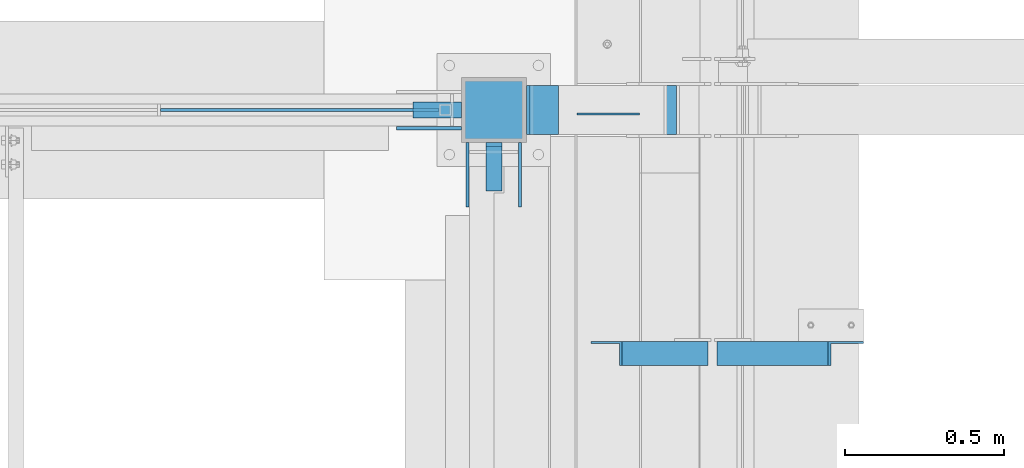
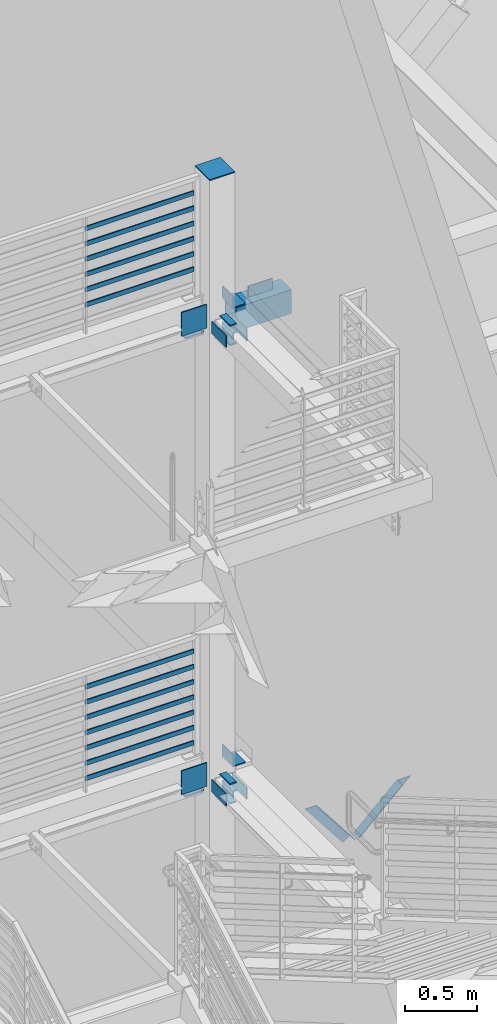
# One storey, part 878 of 1179: 32 beams, 2 members, 9 elements without a shape of their own.
"""IFC2X3 building model written with IfcOpenShell, lengths in millimetres."""

from ifc_helpers import new_model, si_unit, frame, origin_with_axes, place, context, subcontext, project, spatial, faceted_brep, material, type_object, element, aggregate, save


model = new_model("IFC2X3")

# Units and contexts
model_context = context("Model", 3, precision=1e-05, world=origin_with_axes())
body_context = subcontext(model_context, "Body", "Model", "MODEL_VIEW")
ifc_project = project(units=[si_unit("LENGTHUNIT", "METRE", prefix="MILLI"), si_unit("AREAUNIT", "SQUARE_METRE"), si_unit("VOLUMEUNIT", "CUBIC_METRE"), si_unit("MASSUNIT", "GRAM", prefix="KILO"), si_unit("TIMEUNIT", "SECOND"), si_unit("PLANEANGLEUNIT", "RADIAN"), si_unit("SOLIDANGLEUNIT", "STERADIAN"), si_unit("THERMODYNAMICTEMPERATUREUNIT", "DEGREE_CELSIUS"), si_unit("LUMINOUSINTENSITYUNIT", "LUMEN")], contexts=[model_context])

# Site, building, storey
site_placement = place(None, origin_with_axes())
site = spatial("IfcSite", under=ifc_project, at=site_placement, CompositionType="ELEMENT")
building_placement = place(site_placement, origin_with_axes())
building = spatial("IfcBuilding", under=site, at=building_placement, Name="Undefined", CompositionType="ELEMENT")
storey_placement = place(building_placement, origin_with_axes())
storey = spatial("IfcBuildingStorey", under=building, at=storey_placement, Name="Undefined", CompositionType="ELEMENT", Elevation=0.0)

# Assembly, beam
assembly_1_placement = place(storey_placement, origin_with_axes())
assembly_1 = element("IfcElementAssembly", 1, at=assembly_1_placement, inside=storey, Name="PLATE", AssemblyPlace="NOTDEFINED", PredefinedType="RIGID_FRAME")
ifc_material_1 = material(Name="STEEL/A572-GR.50")
beam_type_1 = type_object("IfcBeamType", PredefinedType="NOTDEFINED")
beam_1_placement = place(assembly_1_placement, frame((-254.000000000004, 37388.8, 8051.8), z_axis=(1.0, 0.0, 0.0), x_axis=(0.0, 1.0, 0.0)))
beam_1 = element("IfcBeam", 2, at=beam_1_placement, type_object=beam_type_1, material=ifc_material_1, Name="PLATE", context=body_context, shape_type="Brep", body=[
    faceted_brep([(152.400000000001, -6.35000000000036, 25.4), (152.400000000001, -6.35000000000036, -25.4), (139.700000000004, 6.35000000000036, -25.4), (139.700000000004, 6.35000000000036, 25.4), (0.0, -6.35000000000036, -25.4000000000015), (0.0, -6.35000000000036, 25.4000000000015), (0.0, 6.35000000000036, 25.4000000000015), (0.0, 6.35000000000036, -25.4000000000015)], [[[0, 1, 2, 3]], [[4, 5, 6, 7]], [[6, 5, 0, 3]], [[7, 6, 3, 2]], [[4, 7, 2, 1]], [[5, 4, 1, 0]]]),
])
aggregate(assembly_1, [beam_1])

# Assembly, beams
assembly_2_placement = place(storey_placement, origin_with_axes())
assembly_2 = element("IfcElementAssembly", 3, at=assembly_2_placement, inside=storey, Name="COLUMN", AssemblyPlace="NOTDEFINED", PredefinedType="RIGID_FRAME")
beam_2_placement = place(assembly_2_placement, frame((-253.999996662751, 37388.8, 7886.7), z_axis=(1.0, 0.0, 0.0), x_axis=(0.0, 1.0, 0.0)))
beam_2 = element("IfcBeam", 4, at=beam_2_placement, type_object=beam_type_1, material=ifc_material_1, Name="PLATE", context=body_context, shape_type="Brep", body=[
    faceted_brep([(152.399999999998, 6.35000000000036, 25.4000000000015), (139.699999999998, -6.35000000000036, 25.4000000000015), (139.699999999998, -6.35000000000036, -25.4000000000015), (152.399999999998, 6.35000000000036, -25.4000000000015), (0.0, -6.35000000000036, -25.4000000000015), (0.0, -6.35000000000036, 25.4000000000015), (0.0, 6.35000000000036, 25.4000000000015), (0.0, 6.35000000000036, -25.4000000000015)], [[[0, 1, 2, 3]], [[4, 5, 6, 7]], [[7, 6, 0, 3]], [[4, 7, 3, 2]], [[5, 4, 2, 1]], [[6, 5, 1, 0]]]),
])
beam_3_placement = place(assembly_2_placement, frame((-254.000000000004, 37388.8, 3975.10000002185), z_axis=(1.0, 0.0, 0.0), x_axis=(0.0, 1.0, 0.0)))
beam_3 = element("IfcBeam", 5, at=beam_3_placement, type_object=beam_type_1, material=ifc_material_1, Name="PLATE", context=body_context, shape_type="Brep", body=[
    faceted_brep([(152.399999999998, 6.35000000000036, 25.4000000000015), (139.699999999998, -6.35000000000036, 25.4000000000015), (139.699999999998, -6.35000000000036, -25.4000000000015), (152.399999999998, 6.35000000000036, -25.4000000000015), (0.0, -6.35000000000036, -25.4000000000015), (0.0, -6.35000000000036, 25.4000000000015), (0.0, 6.35000000000036, 25.4000000000015), (0.0, 6.35000000000036, -25.4000000000015)], [[[0, 1, 2, 3]], [[4, 5, 6, 7]], [[7, 6, 0, 3]], [[4, 7, 3, 2]], [[5, 4, 2, 1]], [[6, 5, 1, 0]]]),
])

# Assembly, beam
assembly_3_placement = place(storey_placement, origin_with_axes())
assembly_3 = element("IfcElementAssembly", 6, at=assembly_3_placement, inside=storey, Name="PLATE", AssemblyPlace="NOTDEFINED", PredefinedType="RIGID_FRAME")
beam_4_placement = place(assembly_3_placement, frame((-254.000000000004, 37388.8, 4140.2), z_axis=(1.0, 0.0, 0.0), x_axis=(0.0, 1.0, 0.0)))
beam_4 = element("IfcBeam", 7, at=beam_4_placement, type_object=beam_type_1, material=ifc_material_1, Name="PLATE", context=body_context, shape_type="Brep", body=[
    faceted_brep([(152.400000000001, -6.35000000000036, 25.4), (152.400000000001, -6.35000000000036, -25.4), (139.700000000004, 6.35000000000036, -25.4), (139.700000000004, 6.35000000000036, 25.4), (0.0, -6.35000000000036, -25.4000000000015), (0.0, -6.35000000000036, 25.4000000000015), (0.0, 6.35000000000036, 25.4000000000015), (0.0, 6.35000000000036, -25.4000000000015)], [[[0, 1, 2, 3]], [[4, 5, 6, 7]], [[6, 5, 0, 3]], [[7, 6, 3, 2]], [[4, 7, 2, 1]], [[5, 4, 1, 0]]]),
])
aggregate(assembly_3, [beam_4])

# Beam
beam_5_placement = place(assembly_2_placement, frame((-508.0, 37642.8, 7886.7), z_axis=(0.0, 1.0, 0.0), x_axis=(1.0, 0.0, 0.0)))
beam_5 = element("IfcBeam", 8, at=beam_5_placement, type_object=beam_type_1, material=ifc_material_1, Name="PLATE", context=body_context, shape_type="Brep", body=[
    faceted_brep([(152.400000000001, -6.35000000000036, 25.4), (152.400000000001, -6.35000000000036, -25.4), (139.700000000004, 6.35000000000036, -25.4), (139.700000000004, 6.35000000000036, 25.4), (0.0, -6.35000000000036, -25.4000000000015), (0.0, -6.35000000000036, 25.4000000000015), (0.0, 6.35000000000036, 25.4000000000015), (0.0, 6.35000000000036, -25.4000000000015)], [[[0, 1, 2, 3]], [[4, 5, 6, 7]], [[6, 5, 0, 3]], [[7, 6, 3, 2]], [[4, 7, 2, 1]], [[5, 4, 1, 0]]]),
])

beam_6_placement = place(assembly_2_placement, frame((-508.0, 37642.8, 3975.1), z_axis=(0.0, 1.0, 0.0), x_axis=(1.0, 0.0, 0.0)))
beam_6 = element("IfcBeam", 9, at=beam_6_placement, type_object=beam_type_1, material=ifc_material_1, Name="PLATE", context=body_context, shape_type="Brep", body=[
    faceted_brep([(152.400000000001, -6.35000000000036, 25.4), (152.400000000001, -6.35000000000036, -25.4), (139.700000000004, 6.35000000000036, -25.4), (139.700000000004, 6.35000000000036, 25.4), (0.0, -6.35000000000036, -25.4000000000015), (0.0, -6.35000000000036, 25.4000000000015), (0.0, 6.35000000000036, 25.4000000000015), (0.0, 6.35000000000036, -25.4000000000015)], [[[0, 1, 2, 3]], [[4, 5, 6, 7]], [[6, 5, 0, 3]], [[7, 6, 3, 2]], [[4, 7, 2, 1]], [[5, 4, 1, 0]]]),
])

ifc_material_2 = material(Name="STEEL/A36")
beam_type_2 = type_object("IfcBeamType", PredefinedType="NOTDEFINED")
beam_7_placement = place(assembly_2_placement, frame((-336.5499966627, 37338.0, 7969.25), z_axis=(0.0, 0.0, 1.0), x_axis=(0.0, 1.0, 0.0)))
beam_7 = element("IfcBeam", 10, at=beam_7_placement, type_object=beam_type_2, material=ifc_material_2, Name="PLATE", context=body_context, shape_type="Brep", body=[
    faceted_brep([(0.0, 4.76249999999982, -50.7999999999993), (0.0, 4.76249999999982, 50.7999999999993), (203.2, 4.76249999999709, 50.7999999999993), (203.2, 4.76249999999709, -50.7999999999993), (0.0, -4.76249999999982, 50.7999999999993), (203.2, -4.76249999999709, 50.7999999999993), (0.0, -4.76249999999982, -50.7999999999993), (203.2, -4.76249999999709, -50.7999999999993)], [[[0, 1, 2, 3]], [[1, 4, 5, 2]], [[4, 6, 7, 5]], [[6, 0, 3, 7]], [[5, 7, 3, 2]], [[6, 4, 1, 0]]]),
])

beam_8_placement = place(assembly_2_placement, frame((-171.449999999997, 37338.0, 7969.25), z_axis=(0.0, 0.0, 1.0), x_axis=(0.0, 1.0, 0.0)))
beam_8 = element("IfcBeam", 11, at=beam_8_placement, type_object=beam_type_2, material=ifc_material_2, Name="PLATE", context=body_context, shape_type="Brep", body=[
    faceted_brep([(0.0, 4.76249999999982, -50.7999999999993), (0.0, 4.76249999999982, 50.7999999999993), (203.2, 4.76249999999709, 50.7999999999993), (203.2, 4.76249999999709, -50.7999999999993), (0.0, -4.76249999999982, 50.7999999999993), (203.2, -4.76249999999709, 50.7999999999993), (0.0, -4.76249999999982, -50.7999999999993), (203.2, -4.76249999999709, -50.7999999999993)], [[[0, 1, 2, 3]], [[1, 4, 5, 2]], [[4, 6, 7, 5]], [[6, 0, 3, 7]], [[5, 7, 3, 2]], [[6, 4, 1, 0]]]),
])

beam_9_placement = place(assembly_2_placement, frame((-336.550000000003, 37338.0, 4057.65), z_axis=(0.0, 0.0, 1.0), x_axis=(0.0, 1.0, 0.0)))
beam_9 = element("IfcBeam", 12, at=beam_9_placement, type_object=beam_type_2, material=ifc_material_2, Name="PLATE", context=body_context, shape_type="Brep", body=[
    faceted_brep([(0.0, 4.76249999999982, -50.7999999999993), (0.0, 4.76249999999982, 50.7999999999993), (203.2, 4.76249999999709, 50.7999999999993), (203.2, 4.76249999999709, -50.7999999999993), (0.0, -4.76249999999982, 50.7999999999993), (203.2, -4.76249999999709, 50.7999999999993), (0.0, -4.76249999999982, -50.7999999999993), (203.2, -4.76249999999709, -50.7999999999993)], [[[0, 1, 2, 3]], [[1, 4, 5, 2]], [[4, 6, 7, 5]], [[6, 0, 3, 7]], [[5, 7, 3, 2]], [[6, 4, 1, 0]]]),
])

beam_10_placement = place(assembly_2_placement, frame((-171.449999999997, 37338.0, 4057.70291819733), z_axis=(0.0, 0.0, 1.0), x_axis=(0.0, 1.0, 0.0)))
beam_10 = element("IfcBeam", 13, at=beam_10_placement, type_object=beam_type_2, material=ifc_material_2, Name="PLATE", context=body_context, shape_type="Brep", body=[
    faceted_brep([(0.0, 4.76249999999982, -50.7999999999993), (0.0, 4.76249999999982, 50.7999999999993), (203.2, 4.76249999999709, 50.7999999999993), (203.2, 4.76249999999709, -50.7999999999993), (0.0, -4.76249999999982, 50.7999999999993), (203.2, -4.76249999999709, 50.7999999999993), (0.0, -4.76249999999982, -50.7999999999993), (203.2, -4.76249999999709, -50.7999999999993)], [[[0, 1, 2, 3]], [[1, 4, 5, 2]], [[4, 6, 7, 5]], [[6, 0, 3, 7]], [[5, 7, 3, 2]], [[6, 4, 1, 0]]]),
])

# Assembly, beams
assembly_4_placement = place(storey_placement, origin_with_axes())
assembly_4 = element("IfcElementAssembly", 14, at=assembly_4_placement, inside=storey, Name="GUARDRAIL", AssemblyPlace="NOTDEFINED", PredefinedType="RIGID_FRAME")
beam_type_3 = type_object("IfcBeamType", PredefinedType="NOTDEFINED")
beam_11_placement = place(assembly_4_placement, frame((-1303.86666666667, 37642.8, 8436.02791839992), z_axis=(0.0, 0.0, 1.0), x_axis=(1.0, 0.0, 0.0)))
beam_11 = element("IfcBeam", 15, at=beam_11_placement, type_object=beam_type_3, material=ifc_material_2, Name="PLATE", context=body_context, shape_type="Brep", body=[
    faceted_brep([(4.76250000197615, 4.76249999999999, -19.0500000000002), (4.76250000197615, 4.76249999999999, 19.0500000000002), (878.416667431667, 4.76249999999709, 19.0499999999993), (878.416667431667, 4.76249999999709, -19.0499999999993), (4.76250000197615, -4.76249999999999, 19.0500000000002), (878.416667431667, -4.76249999999709, 19.0499999999993), (4.76250000197615, -4.76249999999999, -19.0500000000002), (878.416667431667, -4.76249999999709, -19.0499999999993)], [[[0, 1, 2, 3]], [[1, 4, 5, 2]], [[4, 6, 7, 5]], [[6, 0, 3, 7]], [[5, 7, 3, 2]], [[6, 4, 1, 0]]]),
])
beam_12_placement = place(assembly_4_placement, frame((-1303.86666666667, 37642.8, 8566.20291795924), z_axis=(0.0, 0.0, 1.0), x_axis=(1.0, 0.0, 0.0)))
beam_12 = element("IfcBeam", 16, at=beam_12_placement, type_object=beam_type_3, material=ifc_material_2, Name="PLATE", context=body_context, shape_type="Brep", body=[
    faceted_brep([(4.76250000197615, 4.76249999999999, -19.0500000000002), (4.76250000197615, 4.76249999999999, 19.0500000000002), (878.416667431667, 4.76249999999709, 19.0499999999993), (878.416667431667, 4.76249999999709, -19.0499999999993), (4.76250000197615, -4.76249999999999, 19.0500000000002), (878.416667431667, -4.76249999999709, 19.0499999999993), (4.76250000197615, -4.76249999999999, -19.0500000000002), (878.416667431667, -4.76249999999709, -19.0499999999993)], [[[0, 1, 2, 3]], [[1, 4, 5, 2]], [[4, 6, 7, 5]], [[6, 0, 3, 7]], [[5, 7, 3, 2]], [[6, 4, 1, 0]]]),
])
beam_13_placement = place(assembly_4_placement, frame((-1303.86666666667, 37642.8, 8696.37791897238), z_axis=(0.0, 0.0, 1.0), x_axis=(1.0, 0.0, 0.0)))
beam_13 = element("IfcBeam", 17, at=beam_13_placement, type_object=beam_type_3, material=ifc_material_2, Name="PLATE", context=body_context, shape_type="Brep", body=[
    faceted_brep([(4.76250000197615, 4.76249999999999, -19.0500000000002), (4.76250000197615, 4.76249999999999, 19.0500000000002), (878.416667431667, 4.76249999999709, 19.0499999999993), (878.416667431667, 4.76249999999709, -19.0499999999993), (4.76250000197615, -4.76249999999999, 19.0500000000002), (878.416667431667, -4.76249999999709, 19.0499999999993), (4.76250000197615, -4.76249999999999, -19.0500000000002), (878.416667431667, -4.76249999999709, -19.0499999999993)], [[[0, 1, 2, 3]], [[1, 4, 5, 2]], [[4, 6, 7, 5]], [[6, 0, 3, 7]], [[5, 7, 3, 2]], [[6, 4, 1, 0]]]),
])
beam_14_placement = place(assembly_4_placement, frame((-1303.86666666667, 37642.8, 8826.55291897065), z_axis=(0.0, 0.0, 1.0), x_axis=(1.0, 0.0, 0.0)))
beam_14 = element("IfcBeam", 18, at=beam_14_placement, type_object=beam_type_3, material=ifc_material_2, Name="PLATE", context=body_context, shape_type="Brep", body=[
    faceted_brep([(4.76250000197615, 4.76249999999999, -19.0500000000002), (4.76250000197615, 4.76249999999999, 19.0500000000002), (878.416667431667, 4.76249999999709, 19.0499999999993), (878.416667431667, 4.76249999999709, -19.0499999999993), (4.76250000197615, -4.76249999999999, 19.0500000000002), (878.416667431667, -4.76249999999709, 19.0499999999993), (4.76250000197615, -4.76249999999999, -19.0500000000002), (878.416667431667, -4.76249999999709, -19.0499999999993)], [[[0, 1, 2, 3]], [[1, 4, 5, 2]], [[4, 6, 7, 5]], [[6, 0, 3, 7]], [[5, 7, 3, 2]], [[6, 4, 1, 0]]]),
])
beam_15_placement = place(assembly_4_placement, frame((-1303.86666666667, 37642.8, 8956.72791897413), z_axis=(0.0, 0.0, 1.0), x_axis=(1.0, 0.0, 0.0)))
beam_15 = element("IfcBeam", 19, at=beam_15_placement, type_object=beam_type_3, material=ifc_material_2, Name="PLATE", context=body_context, shape_type="Brep", body=[
    faceted_brep([(4.76250000197615, 4.76249999999999, -19.0500000000002), (4.76250000197615, 4.76249999999999, 19.0500000000002), (878.416667431667, 4.76249999999709, 19.0499999999993), (878.416667431667, 4.76249999999709, -19.0499999999993), (4.76250000197615, -4.76249999999999, 19.0500000000002), (878.416667431667, -4.76249999999709, 19.0499999999993), (4.76250000197615, -4.76249999999999, -19.0500000000002), (878.416667431667, -4.76249999999709, -19.0499999999993)], [[[0, 1, 2, 3]], [[1, 4, 5, 2]], [[4, 6, 7, 5]], [[6, 0, 3, 7]], [[5, 7, 3, 2]], [[6, 4, 1, 0]]]),
])
beam_16_placement = place(assembly_4_placement, frame((-1303.86666666667, 37642.8, 9086.90291897937), z_axis=(0.0, 0.0, 1.0), x_axis=(1.0, 0.0, 0.0)))
beam_16 = element("IfcBeam", 20, at=beam_16_placement, type_object=beam_type_3, material=ifc_material_2, Name="PLATE", context=body_context, shape_type="Brep", body=[
    faceted_brep([(4.76250000197615, 4.76249999999999, -19.0500000000002), (4.76250000197615, 4.76249999999999, 19.0500000000002), (878.416667431667, 4.76249999999709, 19.0499999999993), (878.416667431667, 4.76249999999709, -19.0499999999993), (4.76250000197615, -4.76249999999999, 19.0500000000002), (878.416667431667, -4.76249999999709, 19.0499999999993), (4.76250000197615, -4.76249999999999, -19.0500000000002), (878.416667431667, -4.76249999999709, -19.0499999999993)], [[[0, 1, 2, 3]], [[1, 4, 5, 2]], [[4, 6, 7, 5]], [[6, 0, 3, 7]], [[5, 7, 3, 2]], [[6, 4, 1, 0]]]),
])
aggregate(assembly_4, [beam_11, beam_12, beam_13, beam_14, beam_15, beam_16])

assembly_5_placement = place(storey_placement, origin_with_axes())
assembly_5 = element("IfcElementAssembly", 21, at=assembly_5_placement, inside=storey, Name="GUARDRAIL", AssemblyPlace="NOTDEFINED", PredefinedType="RIGID_FRAME")
beam_17_placement = place(assembly_5_placement, frame((-1303.86666666667, 37642.8, 4394.25291764178), z_axis=(0.0, 0.0, 1.0), x_axis=(1.0, 0.0, 0.0)))
beam_17 = element("IfcBeam", 22, at=beam_17_placement, type_object=beam_type_3, material=ifc_material_2, Name="PLATE", context=body_context, shape_type="Brep", body=[
    faceted_brep([(4.76250000197615, 4.76249999999999, -19.0500000000002), (4.76250000197615, 4.76249999999999, 19.0500000000002), (878.416667431667, 4.76249999999709, 19.0499999999993), (878.416667431667, 4.76249999999709, -19.0499999999993), (4.76250000197615, -4.76249999999999, 19.0500000000002), (878.416667431667, -4.76249999999709, 19.0499999999993), (4.76250000197615, -4.76249999999999, -19.0500000000002), (878.416667431667, -4.76249999999709, -19.0499999999993)], [[[0, 1, 2, 3]], [[1, 4, 5, 2]], [[4, 6, 7, 5]], [[6, 0, 3, 7]], [[5, 7, 3, 2]], [[6, 4, 1, 0]]]),
])
beam_18_placement = place(assembly_5_placement, frame((-1303.86666666667, 37642.8, 4524.4279180897), z_axis=(0.0, 0.0, 1.0), x_axis=(1.0, 0.0, 0.0)))
beam_18 = element("IfcBeam", 23, at=beam_18_placement, type_object=beam_type_3, material=ifc_material_2, Name="PLATE", context=body_context, shape_type="Brep", body=[
    faceted_brep([(4.76250000197615, 4.76249999999999, -19.0500000000002), (4.76250000197615, 4.76249999999999, 19.0500000000002), (878.416667431667, 4.76249999999709, 19.0499999999993), (878.416667431667, 4.76249999999709, -19.0499999999993), (4.76250000197615, -4.76249999999999, 19.0500000000002), (878.416667431667, -4.76249999999709, 19.0499999999993), (4.76250000197615, -4.76249999999999, -19.0500000000002), (878.416667431667, -4.76249999999709, -19.0499999999993)], [[[0, 1, 2, 3]], [[1, 4, 5, 2]], [[4, 6, 7, 5]], [[6, 0, 3, 7]], [[5, 7, 3, 2]], [[6, 4, 1, 0]]]),
])
beam_19_placement = place(assembly_5_placement, frame((-1303.86666666667, 37642.8, 4654.60291764902), z_axis=(0.0, 0.0, 1.0), x_axis=(1.0, 0.0, 0.0)))
beam_19 = element("IfcBeam", 24, at=beam_19_placement, type_object=beam_type_3, material=ifc_material_2, Name="PLATE", context=body_context, shape_type="Brep", body=[
    faceted_brep([(4.76250000197615, 4.76249999999999, -19.0500000000002), (4.76250000197615, 4.76249999999999, 19.0500000000002), (878.416667431667, 4.76249999999709, 19.0499999999993), (878.416667431667, 4.76249999999709, -19.0499999999993), (4.76250000197615, -4.76249999999999, 19.0500000000002), (878.416667431667, -4.76249999999709, 19.0499999999993), (4.76250000197615, -4.76249999999999, -19.0500000000002), (878.416667431667, -4.76249999999709, -19.0499999999993)], [[[0, 1, 2, 3]], [[1, 4, 5, 2]], [[4, 6, 7, 5]], [[6, 0, 3, 7]], [[5, 7, 3, 2]], [[6, 4, 1, 0]]]),
])
beam_20_placement = place(assembly_5_placement, frame((-1303.86666666667, 37642.8, 4784.77791866216), z_axis=(0.0, 0.0, 1.0), x_axis=(1.0, 0.0, 0.0)))
beam_20 = element("IfcBeam", 25, at=beam_20_placement, type_object=beam_type_3, material=ifc_material_2, Name="PLATE", context=body_context, shape_type="Brep", body=[
    faceted_brep([(4.76250000197615, 4.76249999999999, -19.0500000000002), (4.76250000197615, 4.76249999999999, 19.0500000000002), (878.416667431667, 4.76249999999709, 19.0499999999993), (878.416667431667, 4.76249999999709, -19.0499999999993), (4.76250000197615, -4.76249999999999, 19.0500000000002), (878.416667431667, -4.76249999999709, 19.0499999999993), (4.76250000197615, -4.76249999999999, -19.0500000000002), (878.416667431667, -4.76249999999709, -19.0499999999993)], [[[0, 1, 2, 3]], [[1, 4, 5, 2]], [[4, 6, 7, 5]], [[6, 0, 3, 7]], [[5, 7, 3, 2]], [[6, 4, 1, 0]]]),
])
beam_21_placement = place(assembly_5_placement, frame((-1303.86666666667, 37642.8, 4914.95291866043), z_axis=(0.0, 0.0, 1.0), x_axis=(1.0, 0.0, 0.0)))
beam_21 = element("IfcBeam", 26, at=beam_21_placement, type_object=beam_type_3, material=ifc_material_2, Name="PLATE", context=body_context, shape_type="Brep", body=[
    faceted_brep([(4.76250000197615, 4.76249999999999, -19.0500000000002), (4.76250000197615, 4.76249999999999, 19.0500000000002), (878.416667431667, 4.76249999999709, 19.0499999999993), (878.416667431667, 4.76249999999709, -19.0499999999993), (4.76250000197615, -4.76249999999999, 19.0500000000002), (878.416667431667, -4.76249999999709, 19.0499999999993), (4.76250000197615, -4.76249999999999, -19.0500000000002), (878.416667431667, -4.76249999999709, -19.0499999999993)], [[[0, 1, 2, 3]], [[1, 4, 5, 2]], [[4, 6, 7, 5]], [[6, 0, 3, 7]], [[5, 7, 3, 2]], [[6, 4, 1, 0]]]),
])
beam_22_placement = place(assembly_5_placement, frame((-1303.86666666667, 37642.8, 5045.12791866391), z_axis=(0.0, 0.0, 1.0), x_axis=(1.0, 0.0, 0.0)))
beam_22 = element("IfcBeam", 27, at=beam_22_placement, type_object=beam_type_3, material=ifc_material_2, Name="PLATE", context=body_context, shape_type="Brep", body=[
    faceted_brep([(4.76250000197615, 4.76249999999999, -19.0500000000002), (4.76250000197615, 4.76249999999999, 19.0500000000002), (878.416667431667, 4.76249999999709, 19.0499999999993), (878.416667431667, 4.76249999999709, -19.0499999999993), (4.76250000197615, -4.76249999999999, 19.0500000000002), (878.416667431667, -4.76249999999709, 19.0499999999993), (4.76250000197615, -4.76249999999999, -19.0500000000002), (878.416667431667, -4.76249999999709, -19.0499999999993)], [[[0, 1, 2, 3]], [[1, 4, 5, 2]], [[4, 6, 7, 5]], [[6, 0, 3, 7]], [[5, 7, 3, 2]], [[6, 4, 1, 0]]]),
])
beam_23_placement = place(assembly_5_placement, frame((-1303.86666666667, 37642.8, 5175.30291866915), z_axis=(0.0, 0.0, 1.0), x_axis=(1.0, 0.0, 0.0)))
beam_23 = element("IfcBeam", 28, at=beam_23_placement, type_object=beam_type_3, material=ifc_material_2, Name="PLATE", context=body_context, shape_type="Brep", body=[
    faceted_brep([(4.76250000197615, 4.76249999999999, -19.0500000000002), (4.76250000197615, 4.76249999999999, 19.0500000000002), (878.416667431667, 4.76249999999709, 19.0499999999993), (878.416667431667, 4.76249999999709, -19.0499999999993), (4.76250000197615, -4.76249999999999, 19.0500000000002), (878.416667431667, -4.76249999999709, 19.0499999999993), (4.76250000197615, -4.76249999999999, -19.0500000000002), (878.416667431667, -4.76249999999709, -19.0499999999993)], [[[0, 1, 2, 3]], [[1, 4, 5, 2]], [[4, 6, 7, 5]], [[6, 0, 3, 7]], [[5, 7, 3, 2]], [[6, 4, 1, 0]]]),
])
aggregate(assembly_5, [beam_17, beam_18, beam_19, beam_20, beam_21, beam_22, beam_23])

# Assembly, member
assembly_6_placement = place(storey_placement, origin_with_axes())
assembly_6 = element("IfcElementAssembly", 29, at=assembly_6_placement, inside=storey, Name="ANGLE", AssemblyPlace="NOTDEFINED", PredefinedType="RIGID_FRAME")
member_type = type_object("IfcMemberType", Name="L3X3X1/4", PredefinedType="NOTDEFINED")
member_1_placement = place(assembly_6_placement, frame((472.414639168561, 36879.2125, 3736.19330123132), z_axis=(0.0, -1.0, 0.0), x_axis=(0.729484494811633, 0.0, 0.683997347823379)))
member_1 = element("IfcMember", 30, at=member_1_placement, type_object=member_type, material=ifc_material_2, Name="ANGLE", ObjectType="L3X3X1/4", context=body_context, shape_type="Brep", body=[
    faceted_brep([(0.0, 38.0999999999985, -38.0999999999999), (0.0, 38.0999999999985, 38.0999999999999), (475.752341075195, 38.0999999999181, 38.1000000000004), (475.752341075195, 38.0999999999181, -38.1000000000004), (0.0, 31.75, 38.1000000000004), (482.524628360803, 31.7499999999177, 38.1000000000004), (0.0, 31.75, -31.75), (482.524628360803, 31.7499999999177, -31.75), (0.0, -38.0999999999985, -31.75), (557.019788502486, -38.1000000000854, -31.75), (0.0, -38.0999999999985, -38.0999999999999), (557.019788502486, -38.1000000000854, -38.1000000000004)], [[[0, 1, 2, 3]], [[1, 4, 5, 2]], [[4, 6, 7, 5]], [[6, 8, 9, 7]], [[8, 10, 11, 9]], [[10, 0, 3, 11]], [[5, 7, 9, 11, 3, 2]], [[10, 8, 6, 4, 1, 0]]]),
])
aggregate(assembly_6, [member_1])

assembly_7_placement = place(storey_placement, origin_with_axes())
assembly_7 = element("IfcElementAssembly", 31, at=assembly_7_placement, inside=storey, Name="ANGLE", AssemblyPlace="NOTDEFINED", PredefinedType="RIGID_FRAME")
member_2_placement = place(assembly_7_placement, frame((80.8196258456446, 36879.2125, 4125.56128839178), z_axis=(0.0, -1.0, 0.0), x_axis=(0.614083067285056, 0.0, -0.789241399366364)))
member_2 = element("IfcMember", 32, at=member_2_placement, type_object=member_type, material=ifc_material_2, Name="ANGLE", ObjectType="L3X3X1/4", context=body_context, shape_type="Brep", body=[
    faceted_brep([(59.3707492954454, 38.0999999999781, -38.1000000000004), (59.3707492954454, 38.0999999999781, 38.1000000000004), (499.083854779058, 38.0999999998585, 38.1000000000004), (499.083854779058, 38.0999999998585, -38.1000000000004), (54.4300207928691, 31.7499999999804, 38.1000000000004), (499.083854779056, 31.7499999998595, 38.1000000000004), (54.4300207928691, 31.7499999999804, -31.75), (499.083854779056, 31.7499999998595, -31.75), (0.0820072645328764, -38.0999999999945, -31.75), (499.083854779043, -38.10000000013, -31.75), (0.0820072645328764, -38.0999999999945, -38.1000000000004), (499.083854779043, -38.10000000013, -38.1000000000004)], [[[0, 1, 2, 3]], [[1, 4, 5, 2]], [[4, 6, 7, 5]], [[6, 8, 9, 7]], [[8, 10, 11, 9]], [[10, 0, 3, 11]], [[5, 7, 9, 11, 3, 2]], [[10, 8, 6, 4, 1, 0]]]),
])
aggregate(assembly_7, [member_2])

# Beam
beam_type_4 = type_object("IfcBeamType", Name="L4X4X3/8", PredefinedType="NOTDEFINED")
beam_24_placement = place(assembly_2_placement, frame((-101.6000025671, 37566.5999997267, 3879.85), z_axis=(1.0, 0.0, 0.0), x_axis=(0.0, 1.0, 0.0)))
beam_24 = element("IfcBeam", 33, at=beam_24_placement, type_object=beam_type_4, material=ifc_material_2, Name="ANGLE", ObjectType="L4X4X3/8", context=body_context, shape_type="Brep", body=[
    faceted_brep([(1.90993887372315e-11, 50.8000000000002, -50.8000000000002), (1.90993887372315e-11, 50.8000000000002, 50.8000000000002), (152.399999968322, 50.8000000000002, 50.8), (152.399999968322, 50.8000000000002, -50.8), (0.0, 41.2750000000015, 50.8000000000029), (152.399999968322, 41.2750000000001, 50.8), (0.0, 41.2750000000015, -41.2750000000015), (152.399999968322, 41.2750000000001, -41.275), (0.0, -50.7999999999993, -41.2750000000015), (152.399999968322, -50.8000000000002, -41.275), (-1.81898940354586e-11, -50.7999999999997, -50.8000000000002), (152.399999968322, -50.8000000000002, -50.8)], [[[0, 1, 2, 3]], [[1, 4, 5, 2]], [[4, 6, 7, 5]], [[6, 8, 9, 7]], [[8, 10, 11, 9]], [[10, 0, 3, 11]], [[5, 7, 9, 11, 3, 2]], [[10, 8, 6, 4, 1, 0]]]),
])

beam_25_placement = place(assembly_2_placement, frame((-101.6000025671, 37566.5999997267, 4186.2375), z_axis=(0.0, 0.0, 1.0), x_axis=(0.0, 1.0, 0.0)))
beam_25 = element("IfcBeam", 34, at=beam_25_placement, type_object=beam_type_4, material=ifc_material_2, Name="ANGLE", ObjectType="L4X4X3/8", context=body_context, shape_type="Brep", body=[
    faceted_brep([(1.90993887372315e-11, 50.8000000000002, -50.8000000000002), (1.90993887372315e-11, 50.8000000000002, 50.8000000000002), (152.399999968322, 50.8000000000002, 50.8), (152.399999968322, 50.8000000000002, -50.8), (0.0, 41.2750000000015, 50.8000000000029), (152.399999968322, 41.2750000000001, 50.8), (0.0, 41.2750000000015, -41.2750000000015), (152.399999968322, 41.2750000000001, -41.275), (0.0, -50.7999999999993, -41.2750000000015), (152.399999968322, -50.8000000000002, -41.275), (-1.81898940354586e-11, -50.7999999999997, -50.8000000000002), (152.399999968322, -50.8000000000002, -50.8)], [[[0, 1, 2, 3]], [[1, 4, 5, 2]], [[4, 6, 7, 5]], [[6, 8, 9, 7]], [[8, 10, 11, 9]], [[10, 0, 3, 11]], [[5, 7, 9, 11, 3, 2]], [[10, 8, 6, 4, 1, 0]]]),
])

beam_26_placement = place(assembly_2_placement, frame((-101.599999968326, 37566.6, 7791.44999867917), z_axis=(1.0, 0.0, 0.0), x_axis=(0.0, 1.0, 0.0)))
beam_26 = element("IfcBeam", 35, at=beam_26_placement, type_object=beam_type_4, material=ifc_material_2, Name="ANGLE", ObjectType="L4X4X3/8", context=body_context, shape_type="Brep", body=[
    faceted_brep([(1.90993887372315e-11, 50.8000000000002, -50.8000000000002), (1.90993887372315e-11, 50.8000000000002, 50.8000000000002), (152.399999968322, 50.8000000000002, 50.8), (152.399999968322, 50.8000000000002, -50.8), (0.0, 41.2750000000015, 50.8000000000029), (152.399999968322, 41.2750000000001, 50.8), (0.0, 41.2750000000015, -41.2750000000015), (152.399999968322, 41.2750000000001, -41.275), (0.0, -50.7999999999993, -41.2750000000015), (152.399999968322, -50.8000000000002, -41.275), (-1.81898940354586e-11, -50.7999999999997, -50.8000000000002), (152.399999968322, -50.8000000000002, -50.8)], [[[0, 1, 2, 3]], [[1, 4, 5, 2]], [[4, 6, 7, 5]], [[6, 8, 9, 7]], [[8, 10, 11, 9]], [[10, 0, 3, 11]], [[5, 7, 9, 11, 3, 2]], [[10, 8, 6, 4, 1, 0]]]),
])

beam_27_placement = place(assembly_2_placement, frame((-101.599999968326, 37566.6, 8097.8375), z_axis=(0.0, 0.0, 1.0), x_axis=(0.0, 1.0, 0.0)))
beam_27 = element("IfcBeam", 36, at=beam_27_placement, type_object=beam_type_4, material=ifc_material_2, Name="ANGLE", ObjectType="L4X4X3/8", context=body_context, shape_type="Brep", body=[
    faceted_brep([(1.90993887372315e-11, 50.8000000000002, -50.8000000000002), (1.90993887372315e-11, 50.8000000000002, 50.8000000000002), (152.399999968322, 50.8000000000002, 50.8), (152.399999968322, 50.8000000000002, -50.8), (0.0, 41.2750000000015, 50.8000000000029), (152.399999968322, 41.2750000000001, 50.8), (0.0, 41.2750000000015, -41.2750000000015), (152.399999968322, 41.2750000000001, -41.275), (0.0, -50.7999999999993, -41.2750000000015), (152.399999968322, -50.8000000000002, -41.275), (-1.81898940354586e-11, -50.7999999999997, -50.8000000000002), (152.399999968322, -50.8000000000002, -50.8)], [[[0, 1, 2, 3]], [[1, 4, 5, 2]], [[4, 6, 7, 5]], [[6, 8, 9, 7]], [[8, 10, 11, 9]], [[10, 0, 3, 11]], [[5, 7, 9, 11, 3, 2]], [[10, 8, 6, 4, 1, 0]]]),
])

beam_type_5 = type_object("IfcBeamType", PredefinedType="NOTDEFINED")
beam_28_placement = place(assembly_2_placement, frame((-254.0, 37541.2, 9228.1375), z_axis=(1.0, 0.0, 0.0), x_axis=(0.0, 1.0, 0.0)))
beam_28 = element("IfcBeam", 37, at=beam_28_placement, type_object=beam_type_5, material=ifc_material_2, Name="PLATE", context=body_context, shape_type="Brep", body=[
    faceted_brep([(0.0, 4.76250000000073, -101.6), (0.0, 4.76250000000073, 101.6), (203.199999999997, 4.76250000000073, 101.6), (203.199999999997, 4.76250000000073, -101.6), (0.0, -4.76250000000073, 101.6), (203.199999999997, -4.76250000000073, 101.6), (0.0, -4.76250000000073, -101.6), (203.199999999997, -4.76250000000073, -101.6)], [[[0, 1, 2, 3]], [[1, 4, 5, 2]], [[4, 6, 7, 5]], [[6, 0, 3, 7]], [[5, 7, 3, 2]], [[6, 4, 1, 0]]]),
])

beam_29_placement = place(assembly_2_placement, frame((-558.8, 37585.65, 8045.45), z_axis=(0.0, 0.0, 1.0), x_axis=(1.0, 0.0, 0.0)))
beam_29 = element("IfcBeam", 38, at=beam_29_placement, type_object=beam_type_5, material=ifc_material_2, Name="PLATE", context=body_context, shape_type="Brep", body=[
    faceted_brep([(0.0, 4.76250000000073, -101.6), (0.0, 4.76250000000073, 101.6), (203.199999999997, 4.76250000000073, 101.6), (203.199999999997, 4.76250000000073, -101.6), (0.0, -4.76250000000073, 101.6), (203.199999999997, -4.76250000000073, 101.6), (0.0, -4.76250000000073, -101.6), (203.199999999997, -4.76250000000073, -101.6)], [[[0, 1, 2, 3]], [[1, 4, 5, 2]], [[4, 6, 7, 5]], [[6, 0, 3, 7]], [[5, 7, 3, 2]], [[6, 4, 1, 0]]]),
])

beam_30_placement = place(assembly_2_placement, frame((-558.8, 37585.65, 4133.85), z_axis=(0.0, 0.0, 1.0), x_axis=(1.0, 0.0, 0.0)))
beam_30 = element("IfcBeam", 39, at=beam_30_placement, type_object=beam_type_5, material=ifc_material_2, Name="PLATE", context=body_context, shape_type="Brep", body=[
    faceted_brep([(0.0, 4.76250000000073, -101.6), (0.0, 4.76250000000073, 101.6), (203.199999999997, 4.76250000000073, 101.6), (203.199999999997, 4.76250000000073, -101.6), (0.0, -4.76250000000073, 101.6), (203.199999999997, -4.76250000000073, 101.6), (0.0, -4.76250000000073, -101.6), (203.199999999997, -4.76250000000073, -101.6)], [[[0, 1, 2, 3]], [[1, 4, 5, 2]], [[4, 6, 7, 5]], [[6, 0, 3, 7]], [[5, 7, 3, 2]], [[6, 4, 1, 0]]]),
])

aggregate(assembly_2, [beam_7, beam_8, beam_2, beam_9, beam_10, beam_3, beam_28, beam_29, beam_5, beam_30, beam_6, beam_24, beam_25, beam_26, beam_27])

# Assembly, beam
assembly_8_placement = place(storey_placement, origin_with_axes())
assembly_8 = element("IfcElementAssembly", 40, at=assembly_8_placement, inside=storey, Name="BEAM", AssemblyPlace="NOTDEFINED", PredefinedType="RIGID_FRAME")
beam_type_6 = type_object("IfcBeamType", PredefinedType="NOTDEFINED")
beam_31_placement = place(assembly_8_placement, frame((6.34999999682498, 37630.2750452507, 8099.4249941008), z_axis=(0.0, 0.0, 1.0), x_axis=(1.0, 0.0, 0.0)))
beam_31 = element("IfcBeam", 41, at=beam_31_placement, type_object=beam_type_6, material=ifc_material_2, Name="PLATE", context=body_context, shape_type="Brep", body=[
    faceted_brep([(8.88178419700125e-16, 3.17500000000291, -47.625), (8.88178419700125e-16, 3.17500000000291, 47.625), (196.850017626809, 3.17500000062864, 47.625), (196.850017626809, 3.17500000062864, -47.625), (-1.77635683940025e-15, -3.17500000000291, 47.625), (196.850017626809, -3.1749999993699, 47.625), (-1.77635683940025e-15, -3.17500000000291, -47.625), (196.850017626809, -3.1749999993699, -47.625)], [[[0, 1, 2, 3]], [[1, 4, 5, 2]], [[4, 6, 7, 5]], [[6, 0, 3, 7]], [[5, 7, 3, 2]], [[6, 4, 1, 0]]]),
])
aggregate(assembly_8, [beam_31])

assembly_9_placement = place(storey_placement, origin_with_axes())
assembly_9 = element("IfcElementAssembly", 42, at=assembly_9_placement, inside=storey, Name="BEAM", AssemblyPlace="NOTDEFINED", PredefinedType="RIGID_FRAME")
ifc_material_3 = material()
beam_type_7 = type_object("IfcBeamType", Name="HSS8X6X3/8", PredefinedType="NOTDEFINED")
beam_32_placement = place(assembly_9_placement, frame((-139.700001288298, 37642.8, 7943.8499998349), z_axis=(0.0, 0.0, 1.0), x_axis=(1.0, 0.0, 0.0)))
beam_32 = element("IfcBeam", 43, at=beam_32_placement, type_object=beam_type_7, material=ifc_material_3, Name="BEAM", ObjectType="HSS8X6X3/8", context=body_context, shape_type="Brep", body=[
    faceted_brep([(9.52500000002851, 66.6750000000029, -92.0750000000025), (9.52500000002851, -66.6750000000029, -92.0750000000025), (458.787499999206, -66.6750000000029, -92.0750000001444), (458.787499999206, 66.6750000000029, -92.0750000001444), (9.52499999997079, -66.6750000000029, 92.074999999998), (458.787499999148, -66.6750000000029, 92.0749999998561), (9.52499999997079, 66.6750000000029, 92.074999999998), (458.787499999148, 66.6750000000029, 92.0749999998561), (9.52500000003153, 76.1999999999971, -101.600000000002), (9.52499999996778, 76.1999999999971, 101.599999999998), (458.787499999145, 76.1999999999971, 101.599999999856), (458.787499999209, 76.1999999999971, -101.600000000144), (9.52499999996778, -76.1999999999971, 101.599999999998), (458.787499999145, -76.1999999999971, 101.599999999856), (9.52500000003153, -76.1999999999971, -101.600000000002), (458.787499999209, -76.1999999999971, -101.600000000144)], [[[0, 1, 2, 3]], [[1, 4, 5, 2]], [[4, 6, 7, 5]], [[6, 0, 3, 7]], [[8, 9, 10, 11]], [[9, 12, 13, 10]], [[12, 14, 15, 13]], [[14, 8, 11, 15]], [[13, 15, 11, 10], [5, 7, 3, 2]], [[14, 12, 9, 8], [6, 4, 1, 0]]]),
])
aggregate(assembly_9, [beam_32])

save(model, "model.ifc")
